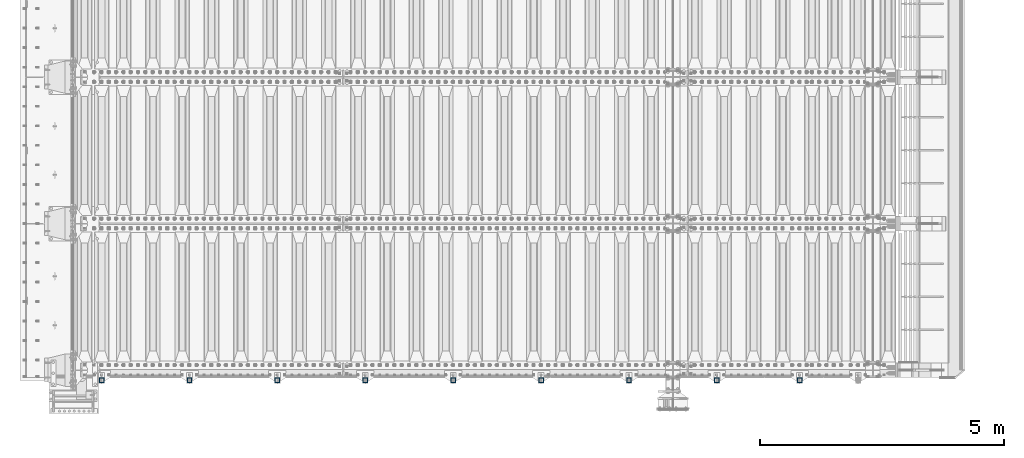
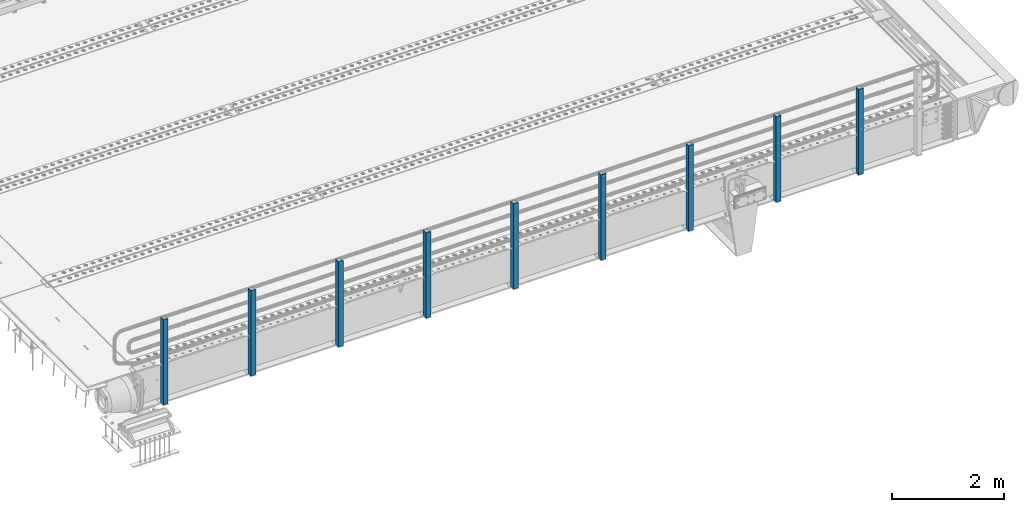
# One storey, part 60 of 257: 9 columns.
"""IFC2X3 building model written with IfcOpenShell, lengths in millimetres."""

from ifc_helpers import new_model, si_unit, frame, origin_with_axes, place, context, subcontext, project, spatial, faceted_brep, material, type_object, element, save


model = new_model("IFC2X3")

# Units and contexts
model_context = context("Model", 3, precision=1e-05, world=origin_with_axes())
body_context = subcontext(model_context, "Body", "Model", "MODEL_VIEW")
ifc_project = project(units=[si_unit("LENGTHUNIT", "METRE", prefix="MILLI"), si_unit("AREAUNIT", "SQUARE_METRE"), si_unit("VOLUMEUNIT", "CUBIC_METRE"), si_unit("MASSUNIT", "GRAM", prefix="KILO"), si_unit("TIMEUNIT", "SECOND"), si_unit("PLANEANGLEUNIT", "RADIAN"), si_unit("SOLIDANGLEUNIT", "STERADIAN"), si_unit("THERMODYNAMICTEMPERATUREUNIT", "DEGREE_CELSIUS"), si_unit("LUMINOUSINTENSITYUNIT", "LUMEN")], contexts=[model_context])

# Site, building, storey
site_placement = place(None, origin_with_axes())
site = spatial("IfcSite", under=ifc_project, at=site_placement, CompositionType="ELEMENT")
building_placement = place(site_placement, origin_with_axes())
building = spatial("IfcBuilding", under=site, at=building_placement, Name="Standard", CompositionType="ELEMENT")
storey_placement = place(building_placement, origin_with_axes())
storey = spatial("IfcBuildingStorey", under=building, at=storey_placement, Name="Undefined", CompositionType="ELEMENT", Elevation=0.0)

# Columns
ifc_material = material()
column_type = type_object("IfcColumnType", PredefinedType="NOTDEFINED")
for number, where, z_axis, x_axis in (
    (1, (57294.9999999999, -210.000000000206, -844.999999999998), (0.0, 1.0, 0.0), (0.0, 0.0, 1.0)),
    (2, (55599.9999999999, -210.000000000206, -844.999999999998), (0.0, 1.0, 0.0), (0.0, 0.0, 1.0)),
    (3, (53799.9999999999, -210.000000000206, -844.999999999998), (0.0, 1.0, 0.0), (0.0, 0.0, 1.0)),
    (4, (51999.9999999999, -210.000000000206, -844.999999999998), (0.0, 1.0, 0.0), (0.0, 0.0, 1.0)),
    (5, (50199.9999999999, -210.000000000206, -844.999999999998), (0.0, 1.0, 0.0), (0.0, 0.0, 1.0)),
    (6, (48399.9999999999, -210.000000000206, -844.999999999998), (0.0, 1.0, 0.0), (0.0, 0.0, 1.0)),
    (7, (46599.9999999999, -210.000000000206, -844.999999999998), (0.0, 1.0, 0.0), (0.0, 0.0, 1.0)),
    (8, (44799.9999999999, -210.000000000206, -844.999999999998), (0.0, 1.0, 0.0), (0.0, 0.0, 1.0)),
    (9, (42999.9999999999, -210.000000000206, -844.999999999998), (0.0, 1.0, 0.0), (0.0, 0.0, 1.0)),
):
    element("IfcColumn", number, at=place(storey_placement, frame(where, z_axis=z_axis, x_axis=x_axis)), inside=storey, type_object=column_type, material=ifc_material, context=body_context, shape_type="Brep", body=[
        faceted_brep([(0.0, 40.0, -40.0), (0.0, -40.0, -40.0), (1855.0, -40.0, -40.0), (1855.0, 40.0, -40.0), (0.0, -40.0, 40.0), (1855.0, -40.0, 40.0), (0.0, 40.0, 40.0), (1855.0, 40.0, 40.0), (0.0, 50.0, -50.0), (0.0, 50.0, 50.0), (1855.0, 50.0, 50.0), (1855.0, 50.0, -50.0), (0.0, -50.0, 50.0), (1855.0, -50.0, 50.0), (0.0, -50.0, -50.0), (1855.0, -50.0, -50.0)], [[[0, 1, 2, 3]], [[1, 4, 5, 2]], [[4, 6, 7, 5]], [[6, 0, 3, 7]], [[8, 9, 10, 11]], [[9, 12, 13, 10]], [[12, 14, 15, 13]], [[14, 8, 11, 15]], [[13, 15, 11, 10], [5, 7, 3, 2]], [[14, 12, 9, 8], [6, 4, 1, 0]]]),
    ])

save(model, "model.ifc")
